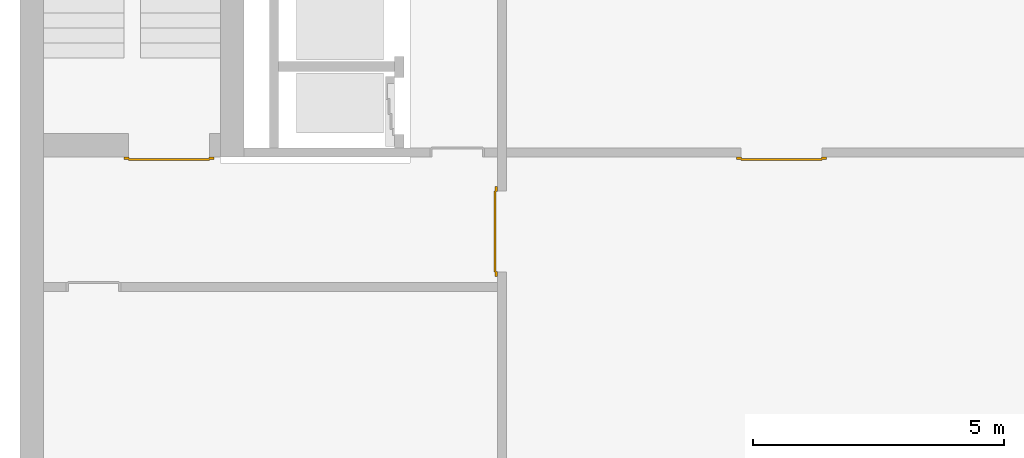
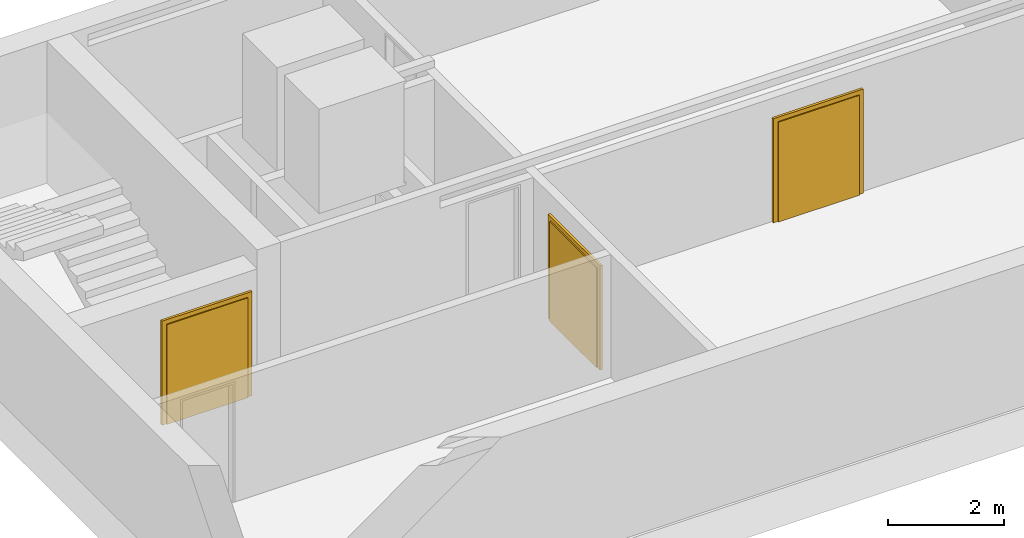
# One storey, part 3 of 5: 3 doors.
"""IFC4 building model written with IfcOpenShell, lengths in metres."""

from ifc_helpers import new_model, entity, si_unit, converted_unit, derived_unit, direction, frame, origin_with_axes, place, context, subcontext, project, spatial, polygons, source, transform, mapped, type_object, element, save


model = new_model("IFC4")

# Units and contexts
model_context = context("Model", 3, precision=1e-05, world=origin_with_axes(), true_north=direction((0.0, 1.0)))
body_context = subcontext(model_context, "Body", "Model", "MODEL_VIEW")
ifc_project = project(units=[si_unit("LENGTHUNIT", "METRE"), si_unit("AREAUNIT", "SQUARE_METRE"), si_unit("VOLUMEUNIT", "CUBIC_METRE"), converted_unit("PLANEANGLEUNIT", "DEGREE", entity("IfcPlaneAngleMeasure", 0.0174532925199433), si_unit("PLANEANGLEUNIT", "RADIAN"), dimensions=[0, 0, 0, 0, 0, 0, 0]), converted_unit("TIMEUNIT", "Year", entity("IfcTimeMeasure", 31557600.0), si_unit("TIMEUNIT", "SECOND"), dimensions=[0, 0, 1, 0, 0, 0, 0]), si_unit("MASSUNIT", "GRAM", prefix="KILO"), si_unit("THERMODYNAMICTEMPERATUREUNIT", "DEGREE_CELSIUS"), si_unit("LUMINOUSINTENSITYUNIT", "LUMEN"), si_unit("ENERGYUNIT", "JOULE", prefix="MEGA"), derived_unit("THERMALCONDUCTANCEUNIT", [(si_unit("POWERUNIT", "WATT"), 1), (si_unit("LENGTHUNIT", "METRE"), -1), (si_unit("THERMODYNAMICTEMPERATUREUNIT", "KELVIN"), -1)]), derived_unit("SPECIFICHEATCAPACITYUNIT", [(si_unit("ENERGYUNIT", "JOULE"), 1), (si_unit("MASSUNIT", "GRAM", prefix="KILO"), -1), (si_unit("THERMODYNAMICTEMPERATUREUNIT", "KELVIN"), -1)]), derived_unit("MASSDENSITYUNIT", [(si_unit("MASSUNIT", "GRAM", prefix="KILO"), 1), (si_unit("VOLUMEUNIT", "CUBIC_METRE"), -1)])], contexts=[model_context])

# Site, building, storey
site_placement = place(None, origin_with_axes())
site = spatial("IfcSite", under=ifc_project, at=site_placement, CompositionType="ELEMENT")
building_placement = place(None, origin_with_axes())
building = spatial("IfcBuilding", under=site, at=building_placement, CompositionType="ELEMENT")
storey_placement = place(None, frame((0.0, 0.0, -3.0), z_axis=(0.0, 0.0, 1.0), x_axis=(1.0, 0.0, 0.0)))
storey = spatial("IfcBuildingStorey", under=building, at=storey_placement, Name="UG", CompositionType="ELEMENT", Elevation=-3.0)

# Doors
door_type = type_object("IfcDoorType", OperationType="DOUBLE_DOOR_SINGLE_SWING", PredefinedType="DOOR")
shared_shape_1 = source(origin_with_axes(), body_context, "Body", "Tessellation", [
    polygons([(-0.9, 0.0, 0.0), (-0.9, 0.0, 2.2), (-0.9, 0.03, 2.2), (-0.9, 0.03, 0.0), (-0.8, 0.0, 0.0), (-0.8, 0.0, 2.1), (-0.1101, 0.0, 2.1), (-0.0001, 0.0, 2.1), (0.8, 0.0, 2.1), (0.8, 0.0, 0.0), (0.9, 0.0, 0.0), (0.9, 0.0, 2.2), (0.9, 0.03, 2.2), (0.9, 0.03, 0.0), (0.8, 0.03, 0.0), (0.8, 0.03, 2.1), (-0.0001, 0.03, 2.1), (-0.1101, 0.03, 2.1), (-0.8, 0.03, 2.1), (-0.8, 0.03, 0.0)], [[[1, 2, 3, 4]], [[1, 5, 6, 7, 8, 9, 10, 11, 12, 2]], [[2, 12, 13, 3]], [[4, 3, 13, 14, 15, 16, 17, 18, 19, 20]], [[5, 1, 4, 20]], [[6, 5, 20, 19]], [[7, 6, 19, 18]], [[8, 7, 18, 17]], [[9, 8, 17, 16]], [[10, 9, 16, 15]], [[11, 10, 15, 14]], [[12, 11, 14, 13]]], closed=True),
    polygons([(-0.9, 0.03, 0.0), (-0.9, 0.03, 2.2), (-0.9, 0.05, 2.2), (-0.9, 0.05, 0.0), (-0.81, 0.03, 0.0), (-0.81, 0.03, 2.11), (-0.1001, 0.03, 2.11), (-0.0101, 0.03, 2.11), (0.81, 0.03, 2.11), (0.81, 0.03, 0.0), (0.9, 0.03, 0.0), (0.9, 0.03, 2.2), (0.9, 0.05, 2.2), (0.9, 0.05, 0.0), (0.81, 0.05, 0.0), (0.81, 0.05, 2.11), (-0.0101, 0.05, 2.11), (-0.1001, 0.05, 2.11), (-0.81, 0.05, 2.11), (-0.81, 0.05, 0.0)], [[[1, 2, 3, 4]], [[1, 5, 6, 7, 8, 9, 10, 11, 12, 2]], [[2, 12, 13, 3]], [[4, 3, 13, 14, 15, 16, 17, 18, 19, 20]], [[5, 1, 4, 20]], [[6, 5, 20, 19]], [[7, 6, 19, 18]], [[8, 7, 18, 17]], [[9, 8, 17, 16]], [[10, 9, 16, 15]], [[11, 10, 15, 14]], [[12, 11, 14, 13]]], closed=True),
    polygons([(-0.81, 0.07, 0.0), (-0.81, 0.07, 2.11), (-0.000499999999999945, 0.07, 2.11), (-0.000499999999999945, 0.07, 0.0), (-0.81, 0.03, 0.0), (-0.81, 0.03, 2.11), (-0.000499999999999945, 0.03, 2.11), (-0.000499999999999945, 0.03, 0.0)], [[[1, 2, 3, 4]], [[1, 5, 6, 2]], [[2, 6, 7, 3]], [[3, 7, 8, 4]], [[4, 8, 5, 1]], [[8, 7, 6, 5]]], closed=True),
    polygons([(0.81, 0.07, 0.0), (0.000499999999999945, 0.07, 0.0), (0.000499999999999945, 0.07, 2.11), (0.81, 0.07, 2.11), (0.81, 0.03, 0.0), (0.000499999999999945, 0.03, 0.0), (0.000499999999999945, 0.03, 2.11), (0.81, 0.03, 2.11)], [[[1, 2, 3, 4]], [[2, 1, 5, 6]], [[3, 2, 6, 7]], [[4, 3, 7, 8]], [[1, 4, 8, 5]], [[6, 5, 8, 7]]], closed=True),
])
door_1_placement = place(None, frame((27.758, 7.05499994546755, -3.0), z_axis=(0.0, 0.0, 1.0), x_axis=(-1.0, 0.0, 0.0)))
element("IfcDoor", 1, at=door_1_placement, inside=storey, type_object=door_type, OverallHeight=2.11, OverallWidth=1.62, context=body_context, shape_type="MappedRepresentation", body=[
    mapped(shared_shape_1, transform((0.800000000000001, 0.0, 0.0))),
])
shared_shape_2 = source(origin_with_axes(), body_context, "Body", "Tessellation", [
    polygons([(-0.9, 0.0, 0.0), (-0.9, 0.0, 2.2), (-0.9, 0.03, 2.2), (-0.9, 0.03, 0.0), (-0.8, 0.0, 0.0), (-0.8, 0.0, 2.1), (-0.1101, 0.0, 2.1), (-0.0001, 0.0, 2.1), (0.8, 0.0, 2.1), (0.8, 0.0, 0.0), (0.9, 0.0, 0.0), (0.9, 0.0, 2.2), (0.9, 0.03, 2.2), (0.9, 0.03, 0.0), (0.8, 0.03, 0.0), (0.8, 0.03, 2.1), (-0.0001, 0.03, 2.1), (-0.1101, 0.03, 2.1), (-0.8, 0.03, 2.1), (-0.8, 0.03, 0.0)], [[[1, 2, 3, 4]], [[1, 5, 6, 7, 8, 9, 10, 11, 12, 2]], [[2, 12, 13, 3]], [[4, 3, 13, 14, 15, 16, 17, 18, 19, 20]], [[5, 1, 4, 20]], [[6, 5, 20, 19]], [[7, 6, 19, 18]], [[8, 7, 18, 17]], [[9, 8, 17, 16]], [[10, 9, 16, 15]], [[11, 10, 15, 14]], [[12, 11, 14, 13]]], closed=True),
    polygons([(-0.9, 0.03, 0.0), (-0.9, 0.03, 2.2), (-0.9, 0.05, 2.2), (-0.9, 0.05, 0.0), (-0.81, 0.03, 0.0), (-0.81, 0.03, 2.11), (-0.1001, 0.03, 2.11), (-0.0101, 0.03, 2.11), (0.81, 0.03, 2.11), (0.81, 0.03, 0.0), (0.9, 0.03, 0.0), (0.9, 0.03, 2.2), (0.9, 0.05, 2.2), (0.9, 0.05, 0.0), (0.81, 0.05, 0.0), (0.81, 0.05, 2.11), (-0.0101, 0.05, 2.11), (-0.1001, 0.05, 2.11), (-0.81, 0.05, 2.11), (-0.81, 0.05, 0.0)], [[[1, 2, 3, 4]], [[1, 5, 6, 7, 8, 9, 10, 11, 12, 2]], [[2, 12, 13, 3]], [[4, 3, 13, 14, 15, 16, 17, 18, 19, 20]], [[5, 1, 4, 20]], [[6, 5, 20, 19]], [[7, 6, 19, 18]], [[8, 7, 18, 17]], [[9, 8, 17, 16]], [[10, 9, 16, 15]], [[11, 10, 15, 14]], [[12, 11, 14, 13]]], closed=True),
    polygons([(-0.81, 0.07, 0.0), (-0.81, 0.07, 2.11), (-0.000499999999999945, 0.07, 2.11), (-0.000499999999999945, 0.07, 0.0), (-0.81, 0.03, 0.0), (-0.81, 0.03, 2.11), (-0.000499999999999945, 0.03, 2.11), (-0.000499999999999945, 0.03, 0.0)], [[[1, 2, 3, 4]], [[1, 5, 6, 2]], [[2, 6, 7, 3]], [[3, 7, 8, 4]], [[4, 8, 5, 1]], [[8, 7, 6, 5]]], closed=True),
    polygons([(0.81, 0.07, 0.0), (0.000499999999999945, 0.07, 0.0), (0.000499999999999945, 0.07, 2.11), (0.81, 0.07, 2.11), (0.81, 0.03, 0.0), (0.000499999999999945, 0.03, 0.0), (0.000499999999999945, 0.03, 2.11), (0.81, 0.03, 2.11)], [[[1, 2, 3, 4]], [[2, 1, 5, 6]], [[3, 2, 6, 7]], [[4, 3, 7, 8]], [[1, 4, 8, 5]], [[6, 5, 8, 7]]], closed=True),
])
door_2_placement = place(None, frame((39.968657642847, 7.05499994546755, -3.0), z_axis=(0.0, 0.0, 1.0), x_axis=(-1.0, 0.0, 0.0)))
element("IfcDoor", 2, at=door_2_placement, inside=storey, type_object=door_type, OverallHeight=2.11, OverallWidth=1.62, context=body_context, shape_type="MappedRepresentation", body=[
    mapped(shared_shape_2, transform((0.799999999999997, 0.0, 0.0))),
])
door_3_placement = place(None, frame((33.505, 4.76499994546756, -3.0), z_axis=(0.0, 0.0, 1.0), x_axis=(0.0, 1.0, 0.0)))
element("IfcDoor", 3, at=door_3_placement, inside=storey, type_object=door_type, OverallHeight=2.11, OverallWidth=1.62, context=body_context, shape_type="MappedRepresentation", body=[
    mapped(shared_shape_2, transform((0.8, 0.0, 0.0))),
])

save(model, "model.ifc")
